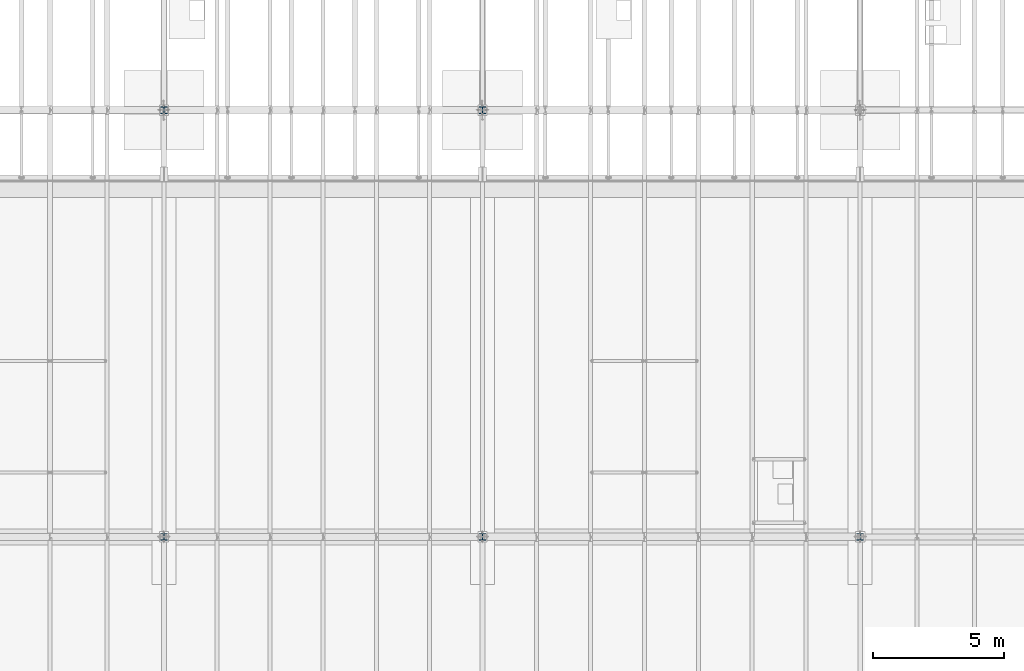
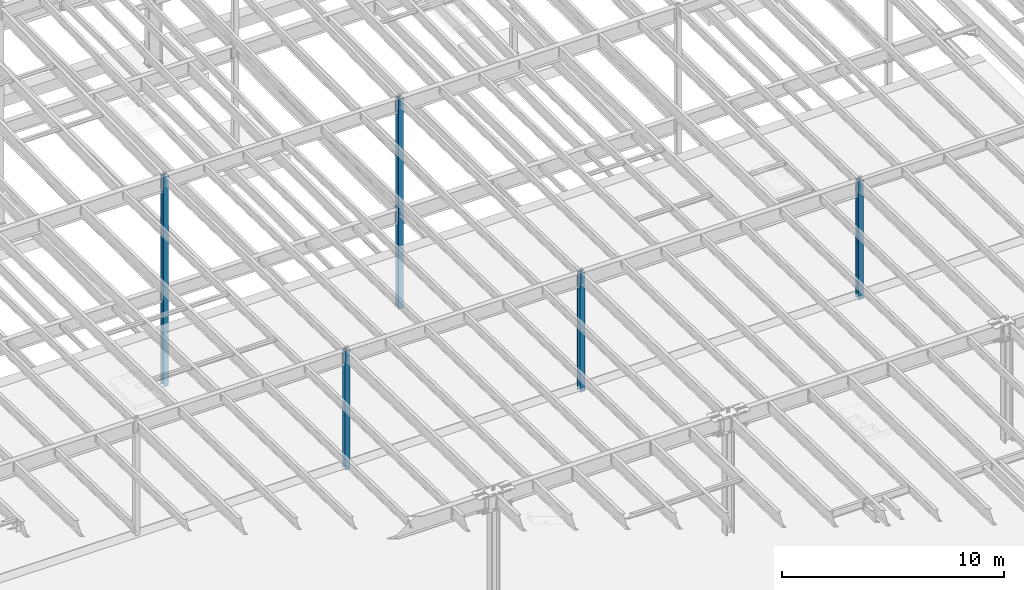
# One storey, part 908 of 1763: 5 columns, 5 elements without a shape of their own.
"""IFC2X3 building model written with IfcOpenShell, lengths in millimetres."""

import ifcopenshell
import ifcopenshell.guid

model = None  # the IFC model being written
_history = None  # IfcOwnerHistory: only IFC2X3 demands one
_inside = {}  # id of a spatial element -> (the spatial element, [elements in it])
_under = {}  # id of a project, library or spatial element -> (it, [spatial elements below it])
_declared = {}  # id of a project -> (the project, [libraries it declares])
_typed = {}  # id of a type object -> (the type object, [elements of that type])
_made_of = {}  # id of a material, layer set ... -> (it, [elements and type objects made of it])


def new_model(schema):
    """Start an empty IFC model of exactly this schema.

    Asked for "IFC4X3", IfcOpenShell would pick the latest addendum, in which some entities
    have other attributes; the version numbers below select the first issue.
    IFC2X3 requires an IfcOwnerHistory on every rooted entity: one is made here for all.
    """
    global model, _history
    if schema == "IFC4X3":
        model = ifcopenshell.file(schema_version=(4, 3, 0, 0))
    else:
        model = ifcopenshell.file(schema=schema)
    _inside.clear()
    _under.clear()
    _declared.clear()
    _typed.clear()
    _made_of.clear()
    _history = None
    if model.schema == "IFC2X3":
        org = make("IfcOrganization", Name="unknown")
        user = make(
            "IfcPersonAndOrganization",
            ThePerson=make("IfcPerson", FamilyName="unknown"),
            TheOrganization=org,
        )
        app = make(
            "IfcApplication",
            ApplicationDeveloper=org,
            Version="unknown",
            ApplicationFullName="unknown",
            ApplicationIdentifier="unknown",
        )
        _history = make(
            "IfcOwnerHistory",
            OwningUser=user,
            OwningApplication=app,
            ChangeAction="ADDED",
            CreationDate=0,
        )
    return model


def make(cls, **values):
    """One entity of the class cls with the attributes given. An attribute that is None is left unset."""
    return model.create_entity(
        cls, **{name: value for name, value in values.items() if value is not None}
    )


def rooted(cls, **values):
    """An entity with a GlobalId (a new one), such as an element, a storey or a relation."""
    return make(cls, GlobalId=ifcopenshell.guid.new(), OwnerHistory=_history, **values)


def si_unit(unit_type, name, prefix=None):
    """IfcSIUnit, for example si_unit("LENGTHUNIT", "METRE", prefix="MILLI")."""
    return make("IfcSIUnit", UnitType=unit_type, Prefix=prefix, Name=name)


def assignment(units):
    """IfcUnitAssignment: the units of a project."""
    return None if units is None else make("IfcUnitAssignment", Units=units)


def point(xyz):
    """IfcCartesianPoint."""
    return None if xyz is None else make("IfcCartesianPoint", Coordinates=xyz)


def direction(xyz):
    """IfcDirection."""
    return None if xyz is None else make("IfcDirection", DirectionRatios=xyz)


def frame(location, z_axis=None, x_axis=None):
    """IfcAxis2Placement3D, a coordinate frame: its origin and axes. An axis left out is left unset."""
    return make(
        "IfcAxis2Placement3D",
        Location=point(location),
        Axis=direction(z_axis),
        RefDirection=direction(x_axis),
    )


def origin_with_axes():
    """The frame at (0, 0, 0) with the z axis (0, 0, 1) and the x axis (1, 0, 0) written out."""
    return frame((0.0, 0.0, 0.0), z_axis=(0.0, 0.0, 1.0), x_axis=(1.0, 0.0, 0.0))


def place(relative_to, where):
    """IfcLocalPlacement: puts the frame where relative to a parent placement (None: the world)."""
    return make(
        "IfcLocalPlacement", PlacementRelTo=relative_to, RelativePlacement=where
    )


def context(
    kind, dimensions, precision=None, world=None, true_north=None, identifier=None
):
    """IfcGeometricRepresentationContext, for example the 3D "Model" context."""
    return make(
        "IfcGeometricRepresentationContext",
        ContextIdentifier=identifier,
        ContextType=kind,
        CoordinateSpaceDimension=dimensions,
        Precision=precision,
        WorldCoordinateSystem=world,
        TrueNorth=true_north,
    )


def subcontext(parent, identifier, kind, view, scale=None):
    """IfcGeometricRepresentationSubContext, for example "Body" below "Model"."""
    return make(
        "IfcGeometricRepresentationSubContext",
        ContextIdentifier=identifier,
        ContextType=kind,
        ParentContext=parent,
        TargetScale=scale,
        TargetView=view,
    )


def project(units=None, contexts=None):
    """IfcProject with its units and contexts."""
    return rooted(
        "IfcProject",
        Name="project",
        RepresentationContexts=contexts,
        UnitsInContext=assignment(units),
    )


def spatial(cls, under=None, at=None, **own):
    """A site, building, storey or space (cls), placed at a placement, below another one or the project."""
    s = rooted(cls, ObjectPlacement=at, **own)
    if under is not None:
        _under.setdefault(under.id(), (under, []))[1].append(s)
    return s


def faces_of(points, faces, orient=None, outer=None):
    """IfcFace entities. A face is a list of loops; a loop is a list of indices into points, from 0.

    orient and outer hold one flag for each loop. By default every Orientation is true, the
    first loop of a face is its IfcFaceOuterBound and the others are IfcFaceBound.
    """
    made = []
    for i, loops in enumerate(faces):
        bounds = []
        for j, loop in enumerate(loops):
            is_outer = j == 0 if outer is None else outer[i][j]
            bounds.append(
                make(
                    "IfcFaceOuterBound" if is_outer else "IfcFaceBound",
                    Bound=make("IfcPolyLoop", Polygon=[points[k] for k in loop]),
                    Orientation=True if orient is None else orient[i][j],
                )
            )
        made.append(make("IfcFace", Bounds=bounds))
    return made


def faceted_brep(points, faces, orient=None, outer=None, voids=None):
    """IfcFacetedBrep: a solid bounded by flat faces; with voids (closed shells), ...WithVoids."""
    shared = [point(p) for p in points]
    hull = make("IfcClosedShell", CfsFaces=faces_of(shared, faces, orient, outer))
    if voids is None:
        return make("IfcFacetedBrep", Outer=hull)
    return make(
        "IfcFacetedBrepWithVoids",
        Outer=hull,
        Voids=[
            make(cls, CfsFaces=faces_of(shared, fs, o, b)) for cls, fs, o, b in voids
        ],
    )


def shape(context_of_items, identifier, shape_type, items):
    """IfcShapeRepresentation: the items that make up one representation, for example the "Body"."""
    return make(
        "IfcShapeRepresentation",
        ContextOfItems=context_of_items,
        RepresentationIdentifier=identifier,
        RepresentationType=shape_type,
        Items=items,
    )


def material(Name=None, Category=None):
    """IfcMaterial."""
    return make("IfcMaterial", Name=Name, Category=Category)


def made_of(thing, what):
    """Note that an element or type object is made of a material, layer set ...; save() writes the relation."""
    if what is not None:
        _made_of.setdefault(what.id(), (what, []))[1].append(thing)
    return thing


def type_object(cls, material=None, **own):
    """A type object (cls), such as IfcWallType, which elements share."""
    return made_of(rooted(cls, **own), material)


def element(
    cls,
    number,
    at=None,
    inside=None,
    cuts=None,
    type_object=None,
    material=None,
    context=None,
    identifier="Body",
    shape_type=None,
    held_by="IfcProductDefinitionShape",
    body=None,
    shapes=None,
    **own,
):
    """One element of the class cls, such as IfcWall. Its Tag is "e" and its number.

    at: its placement. inside: the storey or other place that contains it. cuts: it is an
    opening in that element (IfcRelVoidsElement). A single representation is given by context,
    identifier, shape_type and body (its items); several are given by shapes. held_by: the class
    of the entity that holds the representations. save() writes the other relations.
    """
    e = rooted(cls, Tag="e%d" % number, ObjectPlacement=at, **own)
    if body is not None:
        shapes = [shape(context, identifier, shape_type, body)]
    if shapes is not None:
        e.Representation = make(held_by, Representations=shapes)
    if inside is not None:
        _inside.setdefault(inside.id(), (inside, []))[1].append(e)
    if cuts is not None:
        rooted(
            "IfcRelVoidsElement", RelatingBuildingElement=cuts, RelatedOpeningElement=e
        )
    if type_object is not None:
        _typed.setdefault(type_object.id(), (type_object, []))[1].append(e)
    return made_of(e, material)


def aggregate(whole, parts):
    """IfcRelAggregates: a whole, such as a stair, and the parts it consists of."""
    return rooted("IfcRelAggregates", RelatingObject=whole, RelatedObjects=parts)


def save(model, path):
    """Write the relations noted so far, then the file.

    IfcRelAggregates (storeys below a building ...), IfcRelContainedInSpatialStructure (elements
    in a storey), IfcRelDefinesByType, IfcRelAssociatesMaterial and IfcRelDeclares: one each for
    every whole, place, type object, material and project.
    """
    for whole, parts in _under.values():
        aggregate(whole, parts)
    for where, things in _inside.values():
        rooted(
            "IfcRelContainedInSpatialStructure",
            RelatedElements=things,
            RelatingStructure=where,
        )
    for kind, things in _typed.values():
        rooted("IfcRelDefinesByType", RelatedObjects=things, RelatingType=kind)
    for what, things in _made_of.values():
        rooted("IfcRelAssociatesMaterial", RelatedObjects=things, RelatingMaterial=what)
    for by, libraries in _declared.values():
        rooted("IfcRelDeclares", RelatingContext=by, RelatedDefinitions=libraries)
    model.write(path)


model = new_model("IFC2X3")

# Units and contexts
model_context = context("Model", 3, precision=1e-05, world=origin_with_axes())
body_context = subcontext(model_context, "Body", "Model", "MODEL_VIEW")
ifc_project = project(units=[si_unit("LENGTHUNIT", "METRE", prefix="MILLI"), si_unit("AREAUNIT", "SQUARE_METRE"), si_unit("VOLUMEUNIT", "CUBIC_METRE"), si_unit("MASSUNIT", "GRAM", prefix="KILO"), si_unit("TIMEUNIT", "SECOND"), si_unit("PLANEANGLEUNIT", "RADIAN"), si_unit("SOLIDANGLEUNIT", "STERADIAN"), si_unit("THERMODYNAMICTEMPERATUREUNIT", "DEGREE_CELSIUS"), si_unit("LUMINOUSINTENSITYUNIT", "LUMEN")], contexts=[model_context])

# Site, building, storey
site_placement = place(None, origin_with_axes())
site = spatial("IfcSite", under=ifc_project, at=site_placement, CompositionType="ELEMENT")
building_placement = place(site_placement, origin_with_axes())
building = spatial("IfcBuilding", under=site, at=building_placement, Name="Undefined", CompositionType="ELEMENT")
storey_placement = place(building_placement, origin_with_axes())
storey = spatial("IfcBuildingStorey", under=building, at=storey_placement, Name="Undefined", CompositionType="ELEMENT", Elevation=0.0)

# Assembly, column
assembly_1_placement = place(storey_placement, origin_with_axes())
assembly_1 = element("IfcElementAssembly", 1, at=assembly_1_placement, inside=storey, Name="COLUMN", AssemblyPlace="NOTDEFINED", PredefinedType="RIGID_FRAME")
ifc_material = material(Name="STEEL/A992")
column_type_1 = type_object("IfcColumnType", Name="W10X49", PredefinedType="NOTDEFINED")
column_1_placement = place(assembly_1_placement, frame((-61594.4372736983, 13690.6, 5029.2), z_axis=(0.0, 1.0, 0.0), x_axis=(0.0, 0.0, 1.0)))
column_1 = element("IfcColumn", 2, at=column_1_placement, type_object=column_type_1, material=ifc_material, Name="COLUMN", ObjectType="W10X49", context=body_context, shape_type="Brep", body=[
    faceted_brep([(69.8500000000085, 127.0, -127.0), (69.8500000000085, 127.0, -112.712500000001), (6589.7125, 127.0, -112.7125), (6589.7125, 127.0, -127.0), (69.8500000000085, 3.96875, -112.712500000001), (6589.7125, 3.96875, -112.7125), (69.8500000000085, 3.96875, 112.712500000001), (6589.7125, 3.96875, 112.7125), (69.8500000000085, 127.0, 112.712500000001), (6589.7125, 127.0, 112.7125), (69.8500000000085, 127.0, 127.0), (6589.7125, 127.0, 127.0), (69.8500000000085, -127.0, 127.0), (6589.7125, -127.0, 127.0), (69.8500000000085, -127.0, 112.712500000001), (6589.7125, -127.0, 112.7125), (69.8500000000085, -3.96875, 112.712500000001), (6589.7125, -3.96875, 112.7125), (69.8500000000085, -3.96875, -112.712500000001), (6589.7125, -3.96875, -112.7125), (69.8500000000085, -127.0, -112.712500000001), (6589.7125, -127.0, -112.7125), (69.8500000000085, -127.0, -127.0), (6589.7125, -127.0, -127.0)], [[[0, 1, 2, 3]], [[1, 4, 5, 2]], [[4, 6, 7, 5]], [[6, 8, 9, 7]], [[8, 10, 11, 9]], [[10, 12, 13, 11]], [[12, 14, 15, 13]], [[14, 16, 17, 15]], [[16, 18, 19, 17]], [[18, 20, 21, 19]], [[20, 22, 23, 21]], [[22, 0, 3, 23]], [[5, 7, 9, 11, 13, 15, 17, 19, 21, 23, 3, 2]], [[22, 20, 18, 16, 14, 12, 10, 8, 6, 4, 1, 0]]]),
])
aggregate(assembly_1, [column_1])

assembly_2_placement = place(storey_placement, origin_with_axes())
assembly_2 = element("IfcElementAssembly", 3, at=assembly_2_placement, inside=storey, Name="COLUMN", AssemblyPlace="NOTDEFINED", PredefinedType="RIGID_FRAME")
column_2_placement = place(assembly_2_placement, frame((-49402.4372736983, 13690.6, 5029.2), z_axis=(0.0, 1.0, 0.0), x_axis=(0.0, 0.0, 1.0)))
column_2 = element("IfcColumn", 4, at=column_2_placement, type_object=column_type_1, material=ifc_material, Name="COLUMN", ObjectType="W10X49", context=body_context, shape_type="Brep", body=[
    faceted_brep([(69.8500000000085, 127.0, -127.0), (69.8500000000085, 127.0, -112.712500000001), (6589.7125, 127.0, -112.7125), (6589.7125, 127.0, -127.0), (69.8500000000085, 3.96875, -112.712500000001), (6589.7125, 3.96875, -112.7125), (69.8500000000085, 3.96875, 112.712500000001), (6589.7125, 3.96875, 112.7125), (69.8500000000085, 127.0, 112.712500000001), (6589.7125, 127.0, 112.7125), (69.8500000000085, 127.0, 127.0), (6589.7125, 127.0, 127.0), (69.8500000000085, -127.0, 127.0), (6589.7125, -127.0, 127.0), (69.8500000000085, -127.0, 112.712500000001), (6589.7125, -127.0, 112.7125), (69.8500000000085, -3.96875, 112.712500000001), (6589.7125, -3.96875, 112.7125), (69.8500000000085, -3.96875, -112.712500000001), (6589.7125, -3.96875, -112.7125), (69.8500000000085, -127.0, -112.712500000001), (6589.7125, -127.0, -112.7125), (69.8500000000085, -127.0, -127.0), (6589.7125, -127.0, -127.0)], [[[0, 1, 2, 3]], [[1, 4, 5, 2]], [[4, 6, 7, 5]], [[6, 8, 9, 7]], [[8, 10, 11, 9]], [[10, 12, 13, 11]], [[12, 14, 15, 13]], [[14, 16, 17, 15]], [[16, 18, 19, 17]], [[18, 20, 21, 19]], [[20, 22, 23, 21]], [[22, 0, 3, 23]], [[5, 7, 9, 11, 13, 15, 17, 19, 21, 23, 3, 2]], [[22, 20, 18, 16, 14, 12, 10, 8, 6, 4, 1, 0]]]),
])
aggregate(assembly_2, [column_2])

assembly_3_placement = place(storey_placement, origin_with_axes())
assembly_3 = element("IfcElementAssembly", 5, at=assembly_3_placement, inside=storey, Name="COLUMN", AssemblyPlace="NOTDEFINED", PredefinedType="RIGID_FRAME")
column_3_placement = place(assembly_3_placement, frame((-34949.8372736984, 13690.6, 5029.2), z_axis=(0.0, 1.0, 0.0), x_axis=(0.0, 0.0, 1.0)))
column_3 = element("IfcColumn", 6, at=column_3_placement, type_object=column_type_1, material=ifc_material, Name="COLUMN", ObjectType="W10X49", context=body_context, shape_type="Brep", body=[
    faceted_brep([(69.8500000000085, 127.0, -127.0), (69.8500000000085, 127.0, -112.712500000001), (6589.7125, 127.0, -112.7125), (6589.7125, 127.0, -127.0), (69.8500000000085, 3.96875, -112.712500000001), (6589.7125, 3.96875, -112.7125), (69.8500000000085, 3.96875, 112.712500000001), (6589.7125, 3.96875, 112.7125), (69.8500000000085, 127.0, 112.712500000001), (6589.7125, 127.0, 112.7125), (69.8500000000085, 127.0, 127.0), (6589.7125, 127.0, 127.0), (69.8500000000085, -127.0, 127.0), (6589.7125, -127.0, 127.0), (69.8500000000085, -127.0, 112.712500000001), (6589.7125, -127.0, 112.7125), (69.8500000000085, -3.96875, 112.712500000001), (6589.7125, -3.96875, 112.7125), (69.8500000000085, -3.96875, -112.712500000001), (6589.7125, -3.96875, -112.7125), (69.8500000000085, -127.0, -112.712500000001), (6589.7125, -127.0, -112.7125), (69.8500000000085, -127.0, -127.0), (6589.7125, -127.0, -127.0)], [[[0, 1, 2, 3]], [[1, 4, 5, 2]], [[4, 6, 7, 5]], [[6, 8, 9, 7]], [[8, 10, 11, 9]], [[10, 12, 13, 11]], [[12, 14, 15, 13]], [[14, 16, 17, 15]], [[16, 18, 19, 17]], [[18, 20, 21, 19]], [[20, 22, 23, 21]], [[22, 0, 3, 23]], [[5, 7, 9, 11, 13, 15, 17, 19, 21, 23, 3, 2]], [[22, 20, 18, 16, 14, 12, 10, 8, 6, 4, 1, 0]]]),
])
aggregate(assembly_3, [column_3])

assembly_4_placement = place(storey_placement, origin_with_axes())
assembly_4 = element("IfcElementAssembly", 7, at=assembly_4_placement, inside=storey, Name="COLUMN", AssemblyPlace="NOTDEFINED", PredefinedType="RIGID_FRAME")
column_type_2 = type_object("IfcColumnType", Name="W10X68", PredefinedType="NOTDEFINED")
column_4_placement = place(assembly_4_placement, frame((-61594.4372736983, 30022.8, -304.8), z_axis=(0.0, 1.0, 0.0), x_axis=(0.0, 0.0, 1.0)))
column_4 = element("IfcColumn", 8, at=column_4_placement, type_object=column_type_2, material=ifc_material, Name="COLUMN", ObjectType="W10X68", context=body_context, shape_type="Brep", body=[
    faceted_brep([(69.8499999999952, 128.587499999994, -131.762500000001), (69.8499999999952, 128.587499999994, -112.712500000001), (11582.3999999952, 128.587499999994, -112.712500000001), (11582.3999999952, 128.587499999994, -131.762500000001), (69.8499999999952, 6.35000000000582, -112.712500000001), (11582.3999999952, 6.35000000000582, -112.712500000001), (69.8499999999952, 6.35000000000582, 112.712500000001), (11582.3999999952, 6.35000000000582, 112.712500000001), (69.8499999999952, 128.587499999994, 112.712500000001), (11582.3999999952, 128.587499999994, 112.712500000001), (69.8499999999952, 128.587499999994, 131.762500000001), (11582.3999999952, 128.587499999994, 131.762500000001), (69.8499999999952, -128.587499999994, 131.762500000001), (11582.3999999952, -128.587499999994, 131.762500000001), (69.8499999999952, -128.587499999994, 112.712500000001), (11582.3999999952, -128.587499999994, 112.712500000001), (69.8499999999952, -6.35000000000582, 112.712500000001), (11582.3999999952, -6.35000000000582, 112.712500000001), (69.8499999999952, -6.35000000000582, -112.712500000001), (11582.3999999952, -6.35000000000582, -112.712500000001), (69.8499999999952, -128.587499999994, -112.712500000001), (11582.3999999952, -128.587499999994, -112.712500000001), (69.8499999999952, -128.587499999994, -131.762500000001), (11582.3999999952, -128.587499999994, -131.762500000001)], [[[0, 1, 2, 3]], [[1, 4, 5, 2]], [[4, 6, 7, 5]], [[6, 8, 9, 7]], [[8, 10, 11, 9]], [[10, 12, 13, 11]], [[12, 14, 15, 13]], [[14, 16, 17, 15]], [[16, 18, 19, 17]], [[18, 20, 21, 19]], [[20, 22, 23, 21]], [[22, 0, 3, 23]], [[5, 7, 9, 11, 13, 15, 17, 19, 21, 23, 3, 2]], [[22, 20, 18, 16, 14, 12, 10, 8, 6, 4, 1, 0]]]),
])
aggregate(assembly_4, [column_4])

assembly_5_placement = place(storey_placement, origin_with_axes())
assembly_5 = element("IfcElementAssembly", 9, at=assembly_5_placement, inside=storey, Name="COLUMN", AssemblyPlace="NOTDEFINED", PredefinedType="RIGID_FRAME")
column_5_placement = place(assembly_5_placement, frame((-49402.4372736983, 30022.8, -304.8), z_axis=(0.0, 1.0, 0.0), x_axis=(0.0, 0.0, 1.0)))
column_5 = element("IfcColumn", 10, at=column_5_placement, type_object=column_type_2, material=ifc_material, Name="COLUMN", ObjectType="W10X68", context=body_context, shape_type="Brep", body=[
    faceted_brep([(69.8499999999952, 128.587499999994, -131.762500000001), (69.8499999999952, 128.587499999994, -112.712500000001), (11582.3999999952, 128.587499999994, -112.712500000001), (11582.3999999952, 128.587499999994, -131.762500000001), (69.8499999999952, 6.35000000000582, -112.712500000001), (11582.3999999952, 6.35000000000582, -112.712500000001), (69.8499999999952, 6.35000000000582, 112.712500000001), (11582.3999999952, 6.35000000000582, 112.712500000001), (69.8499999999952, 128.587499999994, 112.712500000001), (11582.3999999952, 128.587499999994, 112.712500000001), (69.8499999999952, 128.587499999994, 131.762500000001), (11582.3999999952, 128.587499999994, 131.762500000001), (69.8499999999952, -128.587499999994, 131.762500000001), (11582.3999999952, -128.587499999994, 131.762500000001), (69.8499999999952, -128.587499999994, 112.712500000001), (11582.3999999952, -128.587499999994, 112.712500000001), (69.8499999999952, -6.35000000000582, 112.712500000001), (11582.3999999952, -6.35000000000582, 112.712500000001), (69.8499999999952, -6.35000000000582, -112.712500000001), (11582.3999999952, -6.35000000000582, -112.712500000001), (69.8499999999952, -128.587499999994, -112.712500000001), (11582.3999999952, -128.587499999994, -112.712500000001), (69.8499999999952, -128.587499999994, -131.762500000001), (11582.3999999952, -128.587499999994, -131.762500000001)], [[[0, 1, 2, 3]], [[1, 4, 5, 2]], [[4, 6, 7, 5]], [[6, 8, 9, 7]], [[8, 10, 11, 9]], [[10, 12, 13, 11]], [[12, 14, 15, 13]], [[14, 16, 17, 15]], [[16, 18, 19, 17]], [[18, 20, 21, 19]], [[20, 22, 23, 21]], [[22, 0, 3, 23]], [[5, 7, 9, 11, 13, 15, 17, 19, 21, 23, 3, 2]], [[22, 20, 18, 16, 14, 12, 10, 8, 6, 4, 1, 0]]]),
])
aggregate(assembly_5, [column_5])

save(model, "model.ifc")
